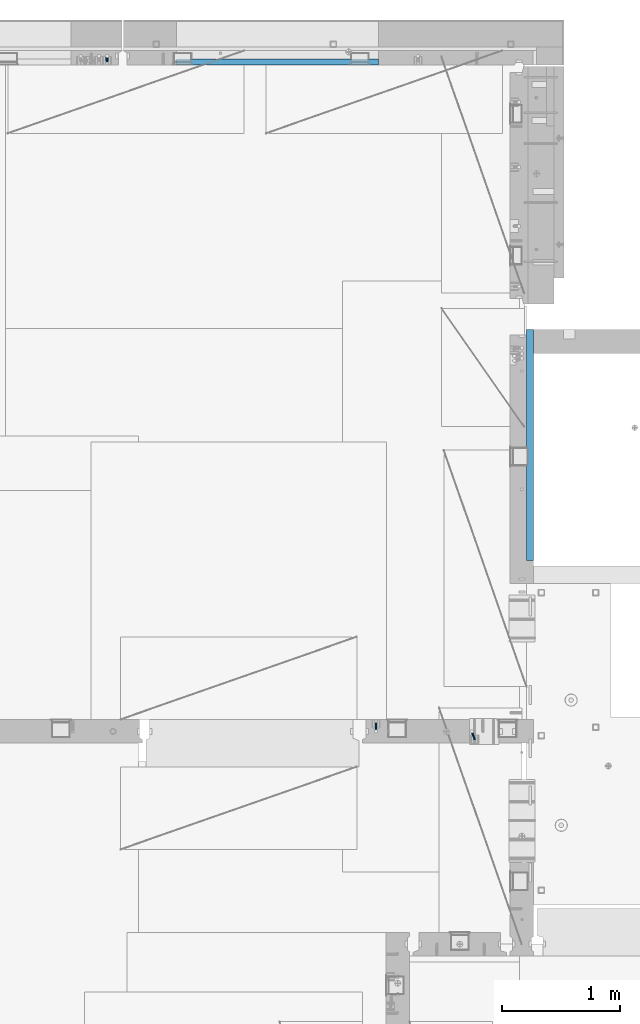
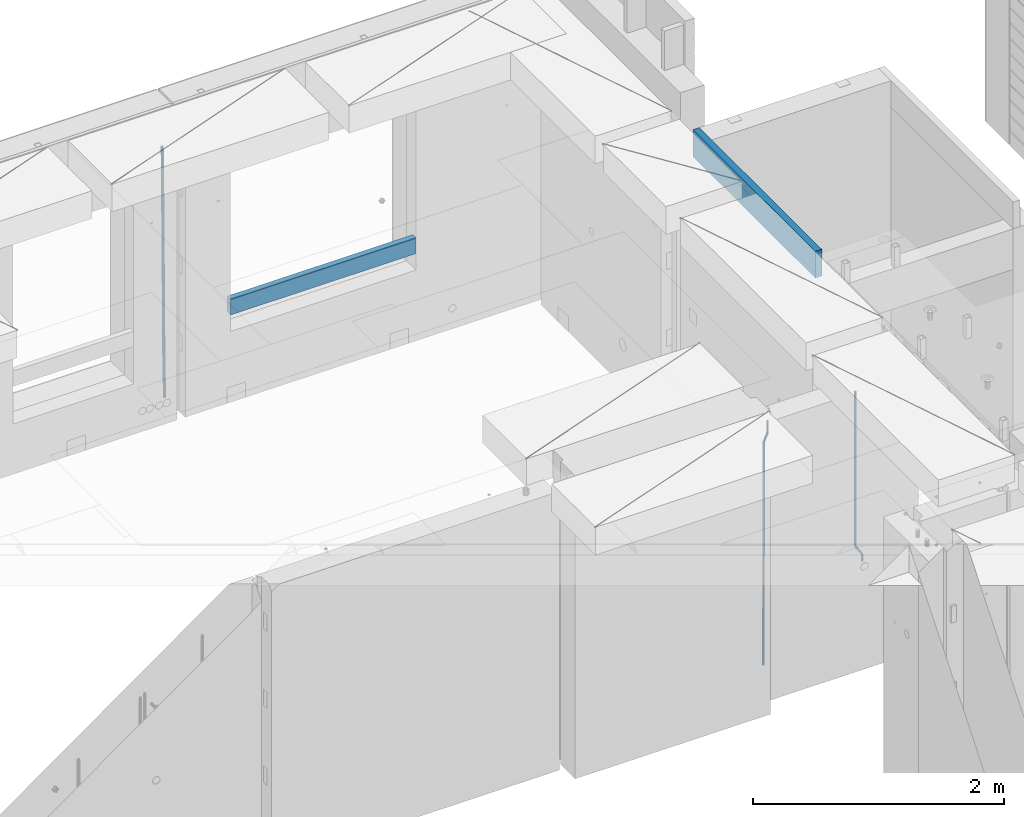
# One storey, part 101 of 309: 6 beams, 5 elements without a shape of their own.
"""IFC2X3 building model written with IfcOpenShell, lengths in millimetres."""

from ifc_helpers import new_model, si_unit, frame, origin_with_axes, place, context, subcontext, project, spatial, faceted_brep, material, type_object, element, aggregate, save


model = new_model("IFC2X3")

# Units and contexts
model_context = context("Model", 3, precision=1e-05, world=origin_with_axes())
body_context = subcontext(model_context, "Body", "Model", "MODEL_VIEW")
ifc_project = project(units=[si_unit("LENGTHUNIT", "METRE", prefix="MILLI"), si_unit("AREAUNIT", "SQUARE_METRE"), si_unit("VOLUMEUNIT", "CUBIC_METRE"), si_unit("MASSUNIT", "GRAM", prefix="KILO"), si_unit("TIMEUNIT", "SECOND"), si_unit("PLANEANGLEUNIT", "RADIAN"), si_unit("SOLIDANGLEUNIT", "STERADIAN"), si_unit("THERMODYNAMICTEMPERATUREUNIT", "DEGREE_CELSIUS"), si_unit("LUMINOUSINTENSITYUNIT", "LUMEN")], contexts=[model_context])

# Site, building, storey
site_placement = place(None, origin_with_axes())
site = spatial("IfcSite", under=ifc_project, at=site_placement, CompositionType="ELEMENT")
building_placement = place(site_placement, origin_with_axes())
building = spatial("IfcBuilding", under=site, at=building_placement, CompositionType="ELEMENT")
storey_placement = place(building_placement, origin_with_axes())
storey = spatial("IfcBuildingStorey", under=building, at=storey_placement, Name="7", CompositionType="ELEMENT", Elevation=0.0)

# Assembly, beams
assembly_1_placement = place(storey_placement, origin_with_axes())
assembly_1 = element("IfcElementAssembly", 1, at=assembly_1_placement, inside=storey, AssemblyPlace="NOTDEFINED", PredefinedType="REINFORCEMENT_UNIT")
ifc_material_1 = material()
beam_type_1 = type_object("IfcBeamType", Name="D20", PredefinedType="NOTDEFINED")
beam_1_placement = place(assembly_1_placement, frame((17285.016478657, 16980.0, 102407.5), z_axis=(-0.000415599999849952, -0.999999913638316, 0.0), x_axis=(-6.05680000062309e-05, -4.00000390151988e-09, -0.999999998165759)))
beam_1 = element("IfcBeam", 2, at=beam_1_placement, type_object=beam_type_1, material=ifc_material_1, Name="JM20", ObjectType="D20", context=body_context, shape_type="Brep", body=[
    faceted_brep([(0.000459931368823163, -9.99999998942076, 0.0), (0.000325058383168653, -7.07106780439426, -7.07106781187031), (1498.53016917036, -7.00214571310062, -7.07110244258729), (1498.53030404639, -9.93107788867201, -3.46394881489687e-05), (0.0, 0.0, -10.0), (1498.52984388257, 0.0689220912790915, -10.0000346307206), (-0.000325382832670584, 7.07106780437971, -7.07106781186667), (1498.52951872915, 7.13998989566971, -7.07110244258365), (-0.000459931412478909, 9.9999999894244, 0.0), (1498.52938418057, 10.0689220807144, -3.46307206200436e-05), (-0.000325058426824398, 7.07106780439062, 7.07106781186667), (1498.52951905355, 7.13998989568427, 7.07103318114605), (0.0, 0.0, 10.0), (1498.52984434133, 0.0689220913009194, 9.99996536927938), (0.000325382789014839, -7.07106780437607, 7.07106781186303), (1498.53016949476, -7.00214571308607, 7.07103318114241), (1512.41720874803, -5.73582294623338, -3.78448857876356), (1509.77427058959, -8.90577003658836, 2.66104918808924), (1506.12781116656, -6.30933666407145, 8.86914963737581), (1503.61387695429, 0.5325217154641, 11.203191722434), (1503.70509651935, 7.6119372551475, 8.29592524499458), (1506.34803467779, 10.7818843455061, 1.85038747814542), (1509.99449410092, 8.18545097300375, -4.35771297110477), (1512.50842831319, 1.34359259344637, -6.6917550561775), (1523.10793428493, 4.85819958866705, 2.43339327473223), (1522.94729923509, -2.24423288682374, 5.28089974098111), (1518.68801206884, 11.068066365151, 3.12656423834051), (1512.27666307625, 12.7477117054659, 6.95436248228361), (1507.62956859401, 8.91322214926913, 11.6745157093537), (1507.46893354415, 1.81078967378926, 14.5220221756208), (1511.88885576031, -4.39907710268017, 13.8288512120525), (1518.30020474852, -6.07872245333419, 10.0010529750907), (1556.47190306216, 16.2553988912259, 53.3150705600565), (1551.82480858495, 12.4209093455574, 58.0352237797015), (1556.63253811194, 23.3578313666767, 50.4675640938258), (1552.2126158958, 29.5676981431861, 51.1607350575687), (1545.80126690332, 31.2473434836029, 54.9885333017664), (1541.1541724212, 27.4128539274789, 59.7086865290003), (1540.99353737144, 20.3104214520208, 62.5561929952273), (1545.41345958759, 14.100554675515, 61.8630220314881), (1560.39637396604, 17.5567067062075, 56.6936612143036), (1557.75345399432, 14.386777545431, 63.1392152562548), (1554.10697584673, 16.9832211248868, 69.3473004384578), (1551.59299696748, 23.8250760096525, 71.6813046576062), (1551.6841720884, 30.9044764000282, 68.7739998967481), (1554.32709206025, 34.0744055607975, 62.3284458548405), (1557.97357020773, 31.4779619813417, 56.1203606726085), (1560.48754908697, 24.6361070965759, 53.7863564534418), (1565.57152260729, 25.0997628321384, 54.9895678972971), (1565.57195097132, 18.0287166318594, 57.9185522284643), (1565.57109441068, 32.1708522292429, 57.9184479422765), (1565.5709172132, 35.0998365550477, 64.9894941556158), (1565.57109481466, 32.1709565155361, 72.0605835657152), (1565.57152317863, 25.0999103152426, 74.9895678968714), (1565.5719513753, 18.0288209181526, 72.0606878518956), (1565.57212857006, 15.0998365824271, 64.9896416479532), (1617.49891294041, 18.0318617339399, 57.9185507229813), (1617.49909054188, 15.1029816944028, 64.9896401330443), (1617.49848457637, 25.1029079342443, 54.989566391796), (1617.49805637961, 32.1739973313524, 57.9184464367172), (1617.49787918197, 35.1029816571718, 64.9894926500019), (1617.49805678344, 32.1741016176347, 72.0605820600649), (1617.49848514747, 25.1030554173267, 74.9895663912539), (1617.49891334424, 18.0319660202294, 72.060686346329)], [[[0, 1, 2, 3]], [[1, 4, 5, 2]], [[4, 6, 7, 5]], [[6, 8, 9, 7]], [[8, 10, 11, 9]], [[10, 12, 13, 11]], [[12, 14, 15, 13]], [[14, 0, 3, 15]], [[14, 12, 10, 8, 6, 4, 1, 0]], [[3, 2, 16, 17]], [[15, 3, 17, 18]], [[13, 15, 18, 19]], [[11, 13, 19, 20]], [[9, 11, 20, 21]], [[7, 9, 21, 22]], [[5, 7, 22, 23]], [[2, 5, 23, 16]], [[23, 24, 25, 16]], [[22, 26, 24, 23]], [[21, 27, 26, 22]], [[20, 28, 27, 21]], [[19, 29, 28, 20]], [[18, 30, 29, 19]], [[17, 31, 30, 18]], [[16, 25, 31, 17]], [[31, 25, 32, 33]], [[25, 24, 34, 32]], [[24, 26, 35, 34]], [[26, 27, 36, 35]], [[27, 28, 37, 36]], [[28, 29, 38, 37]], [[29, 30, 39, 38]], [[30, 31, 33, 39]], [[33, 32, 40, 41]], [[39, 33, 41, 42]], [[38, 39, 42, 43]], [[37, 38, 43, 44]], [[36, 37, 44, 45]], [[35, 36, 45, 46]], [[34, 35, 46, 47]], [[32, 34, 47, 40]], [[47, 48, 49, 40]], [[46, 50, 48, 47]], [[45, 51, 50, 46]], [[44, 52, 51, 45]], [[43, 53, 52, 44]], [[42, 54, 53, 43]], [[41, 55, 54, 42]], [[40, 49, 55, 41]], [[55, 49, 56, 57]], [[49, 48, 58, 56]], [[48, 50, 59, 58]], [[50, 51, 60, 59]], [[51, 52, 61, 60]], [[52, 53, 62, 61]], [[53, 54, 63, 62]], [[54, 55, 57, 63]], [[58, 59, 60, 61, 62, 63, 57, 56]]]),
])
beam_2_placement = place(assembly_1_placement, frame((16475.016478657, 16980.0, 102407.5), z_axis=(-0.000415599999849952, -0.999999913638316, 0.0), x_axis=(-6.05680000062309e-05, -4.00000390151988e-09, -0.999999998165759)))
beam_2 = element("IfcBeam", 3, at=beam_2_placement, type_object=beam_type_1, material=ifc_material_1, Name="JM20", ObjectType="D20", context=body_context, shape_type="Brep", body=[
    faceted_brep([(-0.00060564729210455, -9.99999998165731, 0.0), (-0.000428079845733009, -7.07106779890455, -7.07106781186667), (109.663992146438, -7.07770969181365, -7.07106505070624), (109.663814574931, -10.0066418742208, 2.76014907285571e-06), (0.0, 0.0, -10.0), (109.664420484245, -0.00664189292001538, -9.99999723883957), (0.00042843479604926, 7.07106779888636, -7.07106781186303), (109.66484867355, 7.0644259059809, -7.07106505070988), (0.00060564729210455, 9.99999998166459, 3.63797880709171e-12), (109.665025886861, 9.99335808875549, 2.76115679298528e-06), (0.000428079845733009, 7.07106779890819, 7.07106781186667), (109.664848315049, 7.06442590600273, 7.07107057301982), (0.0, 0.0, 10.0), (109.664419977242, -0.00664189288727357, 10.0000027611604), (-0.000428434810601175, -7.07106779888272, 7.07106781186667), (109.663991787937, -7.07770969179182, 7.07107057302346), (123.019465653822, -0.00769783093346632, 8.49481275451399), (122.368218641306, 7.06342149385819, 5.63932810477127), (120.794596020874, 9.9924781119953, -1.25436342694593), (119.220404581531, 7.06367038153257, -8.14803083615698), (118.567784318744, -0.00734585062309634, -11.0034572490222), (119.219031331319, -7.07846517541839, -8.14797259927946), (120.79265395175, -10.0075217935628, -1.25428106757317), (122.366845391021, -7.07871406308914, 5.63938634164515), (134.432358609134, -7.0801380724879, 1.41616492140383), (135.704448506891, -0.00919495208290755, 4.05476198080942), (131.363125973905, -10.0087693538771, -4.95420191149606), (128.294665451453, -7.07953630984775, -11.3246640276848), (127.024439601548, -0.00834393120385357, -13.9634911148387), (128.296529499246, 7.06259918918295, -11.3248940553931), (131.365762135116, 9.99123047017565, -4.95452722118716), (134.434222657001, 7.06199742654644, 1.41593489364823), (232.333181448281, -7.09406463311461, -61.4435769522424), (235.401641971155, -10.0232976755033, -55.0731148385494), (231.062955598129, -0.0228722546671634, -64.0824040398293), (232.335045495653, 7.04807086590154, -61.4438069808093), (235.404278131435, 9.97670214732716, -55.0734401467271), (238.472738653494, 7.0474691041527, -48.7029780316807), (239.742964503646, -0.0237232742911146, -46.0641509440975), (238.470874606137, -7.09466639485981, -48.7027480031138), (248.152386176487, -0.0244396446978499, -49.0133708264948), (247.497266945589, 7.04670033489674, -51.8679184167595), (245.915123067214, 9.97580676374491, -58.7596380886316), (244.332752967632, 7.04704882145597, -65.6514539264135), (243.677087590491, -0.0239468102772662, -68.5062336817027), (244.33220682136, -7.09508678989368, -65.651686091438), (245.914350699837, -10.0241932187346, -58.7599664195659), (247.496720799376, -7.09543527645292, -51.8681505817658), (256.999396693936, -7.09531210125351, -52.9566469665442), (257.006072236094, -0.0243248818260327, -50.0275278254703), (256.982439129002, -10.0240497531304, -60.0277750206151), (256.965133057005, -7.09492303985826, -67.0987410777925), (256.957616135987, -0.0237746659149707, -70.0274691179584), (256.964291678203, 7.04721255350523, -67.0983499769027), (256.981249241362, 9.97595020465087, -60.027221921624), (256.998555315135, 7.04682349210998, -52.9562558656398), (2308.84129044529, -6.97271028710384, -72.0700484847293), (2308.85859651901, -9.9018369995174, -64.9990824287343), (2308.83377352433, 0.0984380867485015, -74.9987765249425), (2308.84044906651, 7.16942530619053, -72.0696573839123), (2308.85740662973, 10.0981629574344, -64.9985293286554), (2308.87471270347, 7.16903624502447, -57.9275632726531), (2308.88222962443, 0.0978878711684956, -54.9988352324472), (2308.87555408225, -6.9730993482699, -57.9279543734738), (2309.36197244871, -6.97267927451685, -72.0713099986351), (2309.37071429225, -9.90180649703325, -65.000323193126), (2309.3579998037, 0.0984693104364851, -75.0000466259553), (2309.3611234788, 7.16945631832277, -72.0709188794244), (2309.36951366749, 10.0981934592819, -64.9997700670392), (2309.37825551104, 7.16906623676914, -57.9287832615337), (2309.38222815606, 0.0979176518158056, -55.0000466342135), (2309.37910448095, -6.97306935607776, -57.929174380748), (2309.8826559803, -6.97264773775169, -72.0713100117428), (2309.88283356852, -9.90177547898566, -65.0003232060189), (2309.88222762165, 0.0985010618751403, -75.0000466391502), (2309.88179941924, 7.16948785463319, -72.0709188925321), (2309.88162220824, 10.0982244766819, -64.9997700799322), (2309.88179979647, 7.16909673544797, -57.9287832742084), (2309.88222815514, 0.0979479358211393, -55.0000466468009), (2309.88265635754, -6.97303885693691, -57.9291743934191), (2417.50042500655, -6.96612954309967, -72.0713127206036), (2417.50060259478, -9.89525728433364, -65.0003259148798), (2417.49999664789, 0.105019256523519, -75.0000493480147), (2417.49956844548, 7.17600604928157, -72.0709216013965), (2417.49939123449, 10.1047426713303, -64.9997727887931), (2417.49956882271, 7.17561493009634, -57.9287859830729), (2417.49999718138, 0.104466130473156, -55.0000493556618), (2417.50042538378, -6.96652066228489, -57.9291771022799)], [[[0, 1, 2, 3]], [[1, 4, 5, 2]], [[4, 6, 7, 5]], [[6, 8, 9, 7]], [[8, 10, 11, 9]], [[10, 12, 13, 11]], [[12, 14, 15, 13]], [[14, 0, 3, 15]], [[14, 12, 10, 8, 6, 4, 1, 0]], [[11, 13, 16, 17]], [[9, 11, 17, 18]], [[7, 9, 18, 19]], [[5, 7, 19, 20]], [[2, 5, 20, 21]], [[3, 2, 21, 22]], [[15, 3, 22, 23]], [[13, 15, 23, 16]], [[23, 24, 25, 16]], [[22, 26, 24, 23]], [[21, 27, 26, 22]], [[20, 28, 27, 21]], [[19, 29, 28, 20]], [[18, 30, 29, 19]], [[17, 31, 30, 18]], [[16, 25, 31, 17]], [[26, 27, 32, 33]], [[27, 28, 34, 32]], [[28, 29, 35, 34]], [[29, 30, 36, 35]], [[30, 31, 37, 36]], [[31, 25, 38, 37]], [[25, 24, 39, 38]], [[24, 26, 33, 39]], [[37, 38, 40, 41]], [[36, 37, 41, 42]], [[35, 36, 42, 43]], [[34, 35, 43, 44]], [[32, 34, 44, 45]], [[33, 32, 45, 46]], [[39, 33, 46, 47]], [[38, 39, 47, 40]], [[47, 48, 49, 40]], [[46, 50, 48, 47]], [[45, 51, 50, 46]], [[44, 52, 51, 45]], [[43, 53, 52, 44]], [[42, 54, 53, 43]], [[41, 55, 54, 42]], [[40, 49, 55, 41]], [[50, 51, 56, 57]], [[51, 52, 58, 56]], [[52, 53, 59, 58]], [[53, 54, 60, 59]], [[54, 55, 61, 60]], [[55, 49, 62, 61]], [[49, 48, 63, 62]], [[48, 50, 57, 63]], [[57, 56, 64, 65]], [[56, 58, 66, 64]], [[58, 59, 67, 66]], [[59, 60, 68, 67]], [[60, 61, 69, 68]], [[61, 62, 70, 69]], [[62, 63, 71, 70]], [[63, 57, 65, 71]], [[65, 64, 72, 73]], [[64, 66, 74, 72]], [[66, 67, 75, 74]], [[67, 68, 76, 75]], [[68, 69, 77, 76]], [[69, 70, 78, 77]], [[70, 71, 79, 78]], [[71, 65, 73, 79]], [[73, 72, 80, 81]], [[72, 74, 82, 80]], [[74, 75, 83, 82]], [[75, 76, 84, 83]], [[76, 77, 85, 84]], [[77, 78, 86, 85]], [[78, 79, 87, 86]], [[79, 73, 81, 87]], [[82, 83, 84, 85, 86, 87, 81, 80]]]),
])
aggregate(assembly_1, [beam_1, beam_2])

# Assembly, beam
assembly_2_placement = place(storey_placement, origin_with_axes())
assembly_2 = element("IfcElementAssembly", 4, at=assembly_2_placement, inside=storey, AssemblyPlace="NOTDEFINED", PredefinedType="REINFORCEMENT_UNIT")
ifc_material_2 = material(Name="CONCRETE/C25/30")
beam_type_2 = type_object("IfcBeamType", Name="260X60", PredefinedType="NOTDEFINED")
beam_3_placement = place(assembly_2_placement, frame((17779.9999105288, 18424.9992663657, 102600.0), z_axis=(0.0, 0.0, 1.0), x_axis=(0.0, 1.0, 0.0)))
beam_3 = element("IfcBeam", 5, at=beam_3_placement, type_object=beam_type_2, material=ifc_material_2, ObjectType="260X60", context=body_context, shape_type="Brep", body=[
    faceted_brep([(0.0, 30.0, -130.0), (0.0, 30.0, 130.0), (1954.9989445891, 30.0, 130.0), (1954.9989445891, 30.0, -130.0), (0.0, -30.0, 130.0), (1954.9989445891, -30.0, 130.0), (0.0, -30.0, -130.0), (1954.9989445891, -30.0, -130.0)], [[[0, 1, 2, 3]], [[1, 4, 5, 2]], [[4, 6, 7, 5]], [[6, 0, 3, 7]], [[5, 7, 3, 2]], [[6, 4, 1, 0]]]),
])
aggregate(assembly_2, [beam_3])

assembly_3_placement = place(storey_placement, origin_with_axes())
assembly_3 = element("IfcElementAssembly", 6, at=assembly_3_placement, inside=storey, AssemblyPlace="NOTDEFINED", PredefinedType="REINFORCEMENT_UNIT")
beam_type_3 = type_object("IfcBeamType", Name="D25", PredefinedType="NOTDEFINED")
beam_4_placement = place(assembly_3_placement, frame((14200.1300000039, 22654.999995444, 99989.68), z_axis=(-0.000205762999925498, 0.999642804629538, -0.0267249099901004), x_axis=(4.30000201928125e-08, 0.0267249099948059, 0.999642825806181)))
beam_4 = element("IfcBeam", 7, at=beam_4_placement, type_object=beam_type_3, material=ifc_material_1, Name="JM25", ObjectType="D25", context=body_context, shape_type="Brep", body=[
    faceted_brep([(-7.41420080885291e-08, -12.5, -3.63797880709171e-12), (-6.42030499875546e-08, -10.8253175473074, -6.25000000000364), (60.3237677085563, -10.8253175348218, -6.24999999383726), (60.3237677118304, -12.4999999875163, 6.16273609921336e-09), (-3.70782800018787e-08, -6.25000000000364, -10.8253175473074), (60.3237677054713, -6.24999998751628, -10.825317541141), (-1.45519152283669e-11, -3.63797880709171e-12, -12.5), (60.3237677033903, 1.24837242765352e-08, -12.4999999938373), (3.70637280866504e-08, 6.25, -10.8253175473074), (60.323767702881, 6.25000001248372, -10.825317541141), (6.42030499875546e-08, 10.8253175473001, -6.25000000000364), (60.3237677040888, 10.8253175597911, -6.24999999383726), (7.41420080885291e-08, 12.4999999999927, 0.0), (60.3237677066645, 12.5000000124837, 6.15909812040627e-09), (6.42176019027829e-08, 10.8253175473001, 6.24999999999636), (60.3237677099241, 10.8253175597893, 6.25000000616274), (3.70928319171071e-08, 6.24999999999636, 10.8253175473037), (60.3237677130091, 6.25000001248554, 10.8253175534701), (1.45519152283669e-11, -3.63797880709171e-12, 12.4999999999964), (60.3237677151046, 1.24837242765352e-08, 12.5000000061627), (-3.7049176171422e-08, -6.25000000000364, 10.8253175473001), (60.3237677156139, -6.24999998751628, 10.8253175534701), (-6.41884980723262e-08, -10.8253175473074, 6.25), (60.3237677144207, -10.82531753482, 6.25000000616274), (61.0758245489851, -10.8253175346654, -6.24999999375723), (60.991802792938, -12.4999999843931, 6.22458173893392e-09), (61.1373109934648, -6.24999998734893, -10.8253175410573), (61.1598041100515, 1.26583472592756e-08, -12.49999999375), (61.1372768863075, 6.25000001265289, -10.8253175410609), (61.0757654736371, 10.8253175599439, -6.24999999376087), (60.9917690322181, 12.5000000156033, 6.22458173893392e-09), (60.907747276171, 10.8253175599111, 6.25000000622094), (60.8462608316913, 6.25000001259286, 10.8253175535247), (60.8237677151046, 1.25892256619409e-08, 12.5000000062173), (60.8462949388486, -6.24999998740714, 10.825317553521), (60.9078063515044, -10.8253175347018, 6.25000000622458), (61.8276096861373, -10.8253134314764, -6.22978616751061), (61.6596309735614, -12.4999963425144, 0.017955953906494), (61.9505603643775, -6.24999554869282, -10.8034510785947), (61.9955384732893, 4.57403257314581e-06, -12.4775289599711), (61.950492164935, 6.25000445112164, -10.8034519952598), (61.827491561271, 10.8253216628109, -6.22978775521551), (61.6594945747056, 12.5000036571128, 0.0179541205834539), (61.4915158621152, 10.8253207460766, 6.26569624199692), (61.3685651839041, 6.25000286329123, 10.8393611530882), (61.3235870749922, 2.74056583293714e-06, 12.5134390344683), (61.3686333833321, -6.24999713652323, 10.8393620697534), (61.491633986996, -10.8253143482107, 6.26569782971274), (146.560019984419, -10.8248509682762, -3.95152056365259), (146.392041271829, -12.4995338793105, 2.29622155776815), (146.682970662645, -6.24953308548902, -8.52518547473665), (146.727948771557, 0.000467037238195189, -10.1992633561131), (146.682902463217, 6.25046691432544, -8.5251863914018), (146.559901859553, 10.8257841260165, -3.95152215136113), (146.391904872988, 12.5004661203184, 2.29621972444511), (146.223926160397, 10.8257832092804, 8.54396184585858), (146.100975482186, 6.25046532649503, 13.1176267569463), (146.05599737326, 0.000465203767817002, 14.7917046383263), (146.1010436816, -6.24953467331943, 13.1176276736078), (146.224044285264, -10.8248518850105, 8.54396343356711), (147.111078313566, -10.8248479606373, -3.93670383375138), (146.994353869159, -12.4995305919347, 2.31241640066946), (147.196513863179, -6.24953028260825, -8.5113774430065), (147.227768131459, 0.000469765214802464, -10.1858243278657), (147.19646656244, 6.25046971732081, -8.51137779775308), (147.110996386313, 10.8257871338483, -3.93670444818781), (146.994259267696, 12.5004694079234, 2.31241569117628), (146.877534823288, 10.8257867766279, 8.56153592559713), (146.792099273691, 6.25046909859884, 13.1362095348559), (146.760845005425, 0.000469050775791402, 14.8106564197114), (146.792146574429, -6.24953090133022, 13.1362098895952), (146.877616750571, -10.8248483178577, 8.56153654003356), (147.662305566744, -10.824846796575, -3.93093035933998), (147.596851102222, -12.4995293196007, 2.31872686942006), (147.710214487655, -6.24952919779389, -8.50599701707324), (147.727740708287, 0.000470821039925795, -10.1805876875078), (147.710188092009, 6.25047080218064, -8.50599715285716), (147.662259848148, 10.8257882979869, -3.93093059453167), (147.596798310929, 12.5004706803447, 2.31872659784494), (147.531343846407, 10.825788157319, 8.56838382660862), (147.483434925496, 6.25047055853611, 13.1434504843382), (147.465908704849, 0.000470539705929696, 14.8180411547801), (147.483461321142, -6.24952944143479, 13.1434506201294), (147.531389565032, -10.8248469372429, 8.56838406180032), (299.377341023079, -10.8245264100169, -2.34188905237897), (299.311886558571, -12.4992089330408, 3.90776817638471), (299.425249944004, -6.24920881123398, -6.9169557101086), (299.442776164637, 0.000791207598012988, -8.59154638054679), (299.425223548358, 6.25079118874055, -6.91695584589979), (299.377295304497, 10.8261086845469, -2.34188928757067), (299.311833767279, 12.5007910669028, 3.90776790480959), (299.246379302756, 10.8261085438789, 10.1574251335696), (299.198470381845, 6.25079094509601, 14.7324917913029), (299.180944161213, 0.000790926264016889, 16.4070824617411), (299.198496777492, -6.24920905487488, 14.7324919270868), (299.246425021367, -10.8245265506848, 10.157425368765), (299.95725460563, -10.824525185375, -2.33581512151068), (299.97179243555, -12.4991882411778, 3.91467976726199), (299.946633883446, -6.24920771019424, -6.91149481024331), (299.942748741494, 0.000792263424955308, -8.58630974019252), (299.946640200433, 6.25079228984941, -6.91149460340603), (299.957265546982, 10.8261099093088, -2.33581476325344), (299.971750386685, 12.5008117588586, 3.91467993563856), (299.98628821662, 10.8261101063945, 10.1651748323675), (299.996908938818, 6.25079263121188, 14.7408545211001), (300.000794080755, 0.000792657594502089, 16.415669451053), (299.996902621817, -6.24920736882996, 14.7408543142628), (299.986277275268, -10.8245249882893, 10.1651744741102), (300.537133734106, -10.8245269960826, -2.3445816610074), (300.631604424707, -12.4992095999223, 3.90470428084518), (300.467986846197, -6.24920933814974, -6.91937655855145), (300.442691613745, 0.000790702320955461, -8.59386781345165), (300.468025873881, 6.25079066179023, -6.91937684622826), (300.537201332045, 10.8261080984212, -2.34458215927589), (300.631682480074, 12.5007903999558, 3.90470370549519), (300.726153170675, 10.8261077961179, 10.1539896473478), (300.795300058599, 6.25079013818504, 14.7287845448955), (300.82059529105, 0.000790097714343574, 16.403275799792), (300.795261030915, -6.24920986175493, 14.7287848325686), (300.726085572751, -10.8245272983859, 10.1539901456163), (2293.32930409742, -10.8307295605009, -32.4713622331001), (2293.42377478865, -12.5054121599169, -26.2220762900724), (2293.26015720774, -6.2554119058077, -37.0461571338565), (2293.23486197284, -0.00541186651753378, -38.7206483931477), (2293.26019623051, 6.24458809413409, -37.0461574303008), (2293.32937168686, 10.8199055340046, -32.4713627465644), (2293.42385283421, 12.4945878399631, -26.2220768829684), (2293.51832352545, 10.8199052405434, -19.972790939948), (2293.58747041514, 6.24458758585388, -15.3979960391844), (2293.61276565003, -0.00541245343265473, -13.7235047798931), (2293.58743139236, -6.25541241408428, -15.3979957427327), (2293.51825593603, -10.8307298539585, -19.9727904264691), (2294.0420846676, -10.8307317859326, -32.4821379598216), (2294.03681932652, -12.5054140739521, -26.2313442200393), (2294.06778164886, -6.2554144273563, -37.0583666982457), (2294.10702478497, -0.00541458957013674, -38.7338336404937), (2294.14929890928, 6.24458531819619, -37.0595987724118), (2294.18327670435, 10.8199028679592, -32.4842719748667), (2294.1998538474, 12.4945854171456, -26.2338083683717), (2294.19458850632, 10.819903129126, -19.9830146285858), (2294.16889152506, 6.24458577054975, -15.4067858901581), (2294.12964838895, -0.0054140672327776, -13.7313189479173), (2294.08737426462, -6.2554139749991, -15.4055538159919), (2294.05339646956, -10.8307315247621, -19.9808806135297), (2294.75482297382, -10.84002603931, -32.4726521173216), (2294.64982751427, -12.513407826169, -26.2231856868602), (2294.87535820232, -6.26594539088183, -37.0476186524102), (2294.97913588268, -0.0167870967634371, -38.7222267036377), (2295.0383488692, 6.23299192477134, -37.0477663960555), (2295.03713108998, 10.8087684320271, -32.4729080168181), (2294.97580884799, 12.4844668051373, -26.2234811741473), (2294.87081338844, 10.8110850182784, -19.9740147436787), (2294.7502781599, 6.23700436985018, -15.3990482086047), (2294.64650047956, -0.0121539242718427, -13.7244401573698), (2294.58728749304, -6.26193294580662, -15.3989004649666), (2294.58850527227, -10.8377094530588, -19.9737588441894), (2316.44667268227, -11.1228921988077, -32.1839550346631), (2316.34167722271, -12.7962739856739, -25.9344886042054), (2316.56720791078, -6.54881155039038, -36.7589215697517), (2316.67098559113, -0.299653256264719, -38.4335296209792), (2316.73019857766, 5.95012576527006, -36.759069313397), (2316.72898079845, 10.5259022725259, -32.1842109341669), (2316.66765855643, 12.2016006456361, -25.9347840914961), (2316.56266309689, 10.5282188587698, -19.6853176610275), (2316.44212786836, 5.95413821035254, -15.1103511259389), (2316.33835018802, -0.295020083769487, -13.4357430747186), (2316.27913720149, -6.54479910530426, -15.1102033823008), (2316.28035498071, -11.1205756125637, -19.685061761531), (2317.13234804722, -11.1318335458927, -32.1748293731798), (2317.04181141085, -12.8054038787741, -25.9251705100723), (2317.2154741603, -6.5572650749491, -36.7502937866229), (2317.26891617525, -0.307450393454928, -38.4255717558117), (2317.27835434731, 5.94297770185585, -36.7517739018112), (2317.24125972588, 10.5192220504723, -32.1773930078925), (2317.16757178486, 12.1950816748285, -25.9281307404563), (2317.0770351485, 10.5215113419545, -19.6784718773561), (2316.99390903539, 5.94694287101083, -15.1030074639057), (2316.94046702047, -0.302871810494253, -13.4277294947169), (2316.9310288484, -6.55329990579412, -15.1015273487101), (2316.96812346982, -11.1295442544142, -19.6759082426288), (2317.81808136747, -11.1298054502913, -32.1659056455355), (2317.74200467508, -12.803315894289, -25.9160547315114), (2317.86379538118, -6.55536082026447, -36.7418676070083), (2317.8668976831, -0.305700748642266, -38.417815303761), (2317.82655701396, 5.94458339541234, -36.7446799039099), (2317.75358262347, 10.5207330230332, -32.1707766866384), (2317.66752794063, 12.1965725370646, -25.9216793252963), (2317.59145124823, 10.5230620930706, -19.6718284112721), (2317.54573723453, 5.94861746304377, -15.0958664497994), (2317.54263493262, -0.301042608574789, -13.4199187530394), (2317.58297560175, -6.55132675263303, -15.0930541529051), (2317.65594999224, -11.1274763802539, -19.6669573701693), (2417.81884292323, -10.831603083323, -30.8687911350135), (2417.74276623082, -12.505113527317, -24.618940220982), (2417.86455693691, -6.25715845329614, -35.4447530964935), (2417.86765923884, -0.00749838167394046, -37.1207007932499), (2417.82731856969, 6.24278576237703, -35.4475653933878), (2417.75434417921, 10.8189353900088, -30.8736621761236), (2417.66828949639, 12.494774904033, -24.6245648147851), (2417.59221280397, 10.8212644600353, -18.3747139007501), (2417.54649879028, 6.2468198300121, -13.79875193927), (2417.54339648837, -0.00284024161010166, -12.1228042425173), (2417.5837371575, -6.25312438566107, -13.795939642383), (2417.65671154798, -10.8292740132893, -18.3698428596399)], [[[0, 1, 2, 3]], [[1, 4, 5, 2]], [[4, 6, 7, 5]], [[6, 8, 9, 7]], [[8, 10, 11, 9]], [[10, 12, 13, 11]], [[12, 14, 15, 13]], [[14, 16, 17, 15]], [[16, 18, 19, 17]], [[18, 20, 21, 19]], [[20, 22, 23, 21]], [[22, 0, 3, 23]], [[22, 20, 18, 16, 14, 12, 10, 8, 6, 4, 1, 0]], [[3, 2, 24, 25]], [[2, 5, 26, 24]], [[5, 7, 27, 26]], [[7, 9, 28, 27]], [[9, 11, 29, 28]], [[11, 13, 30, 29]], [[13, 15, 31, 30]], [[15, 17, 32, 31]], [[17, 19, 33, 32]], [[19, 21, 34, 33]], [[21, 23, 35, 34]], [[23, 3, 25, 35]], [[25, 24, 36, 37]], [[24, 26, 38, 36]], [[26, 27, 39, 38]], [[27, 28, 40, 39]], [[28, 29, 41, 40]], [[29, 30, 42, 41]], [[30, 31, 43, 42]], [[31, 32, 44, 43]], [[32, 33, 45, 44]], [[33, 34, 46, 45]], [[34, 35, 47, 46]], [[35, 25, 37, 47]], [[37, 36, 48, 49]], [[36, 38, 50, 48]], [[38, 39, 51, 50]], [[39, 40, 52, 51]], [[40, 41, 53, 52]], [[41, 42, 54, 53]], [[42, 43, 55, 54]], [[43, 44, 56, 55]], [[44, 45, 57, 56]], [[45, 46, 58, 57]], [[46, 47, 59, 58]], [[47, 37, 49, 59]], [[49, 48, 60, 61]], [[48, 50, 62, 60]], [[50, 51, 63, 62]], [[51, 52, 64, 63]], [[52, 53, 65, 64]], [[53, 54, 66, 65]], [[54, 55, 67, 66]], [[55, 56, 68, 67]], [[56, 57, 69, 68]], [[57, 58, 70, 69]], [[58, 59, 71, 70]], [[59, 49, 61, 71]], [[61, 60, 72, 73]], [[60, 62, 74, 72]], [[62, 63, 75, 74]], [[63, 64, 76, 75]], [[64, 65, 77, 76]], [[65, 66, 78, 77]], [[66, 67, 79, 78]], [[67, 68, 80, 79]], [[68, 69, 81, 80]], [[69, 70, 82, 81]], [[70, 71, 83, 82]], [[71, 61, 73, 83]], [[73, 72, 84, 85]], [[72, 74, 86, 84]], [[74, 75, 87, 86]], [[75, 76, 88, 87]], [[76, 77, 89, 88]], [[77, 78, 90, 89]], [[78, 79, 91, 90]], [[79, 80, 92, 91]], [[80, 81, 93, 92]], [[81, 82, 94, 93]], [[82, 83, 95, 94]], [[83, 73, 85, 95]], [[85, 84, 96, 97]], [[84, 86, 98, 96]], [[86, 87, 99, 98]], [[87, 88, 100, 99]], [[88, 89, 101, 100]], [[89, 90, 102, 101]], [[90, 91, 103, 102]], [[91, 92, 104, 103]], [[92, 93, 105, 104]], [[93, 94, 106, 105]], [[94, 95, 107, 106]], [[95, 85, 97, 107]], [[97, 96, 108, 109]], [[96, 98, 110, 108]], [[98, 99, 111, 110]], [[99, 100, 112, 111]], [[100, 101, 113, 112]], [[101, 102, 114, 113]], [[102, 103, 115, 114]], [[103, 104, 116, 115]], [[104, 105, 117, 116]], [[105, 106, 118, 117]], [[106, 107, 119, 118]], [[107, 97, 109, 119]], [[109, 108, 120, 121]], [[108, 110, 122, 120]], [[110, 111, 123, 122]], [[111, 112, 124, 123]], [[112, 113, 125, 124]], [[113, 114, 126, 125]], [[114, 115, 127, 126]], [[115, 116, 128, 127]], [[116, 117, 129, 128]], [[117, 118, 130, 129]], [[118, 119, 131, 130]], [[119, 109, 121, 131]], [[121, 120, 132, 133]], [[120, 122, 134, 132]], [[122, 123, 135, 134]], [[123, 124, 136, 135]], [[124, 125, 137, 136]], [[125, 126, 138, 137]], [[126, 127, 139, 138]], [[127, 128, 140, 139]], [[128, 129, 141, 140]], [[129, 130, 142, 141]], [[130, 131, 143, 142]], [[131, 121, 133, 143]], [[133, 132, 144, 145]], [[132, 134, 146, 144]], [[134, 135, 147, 146]], [[135, 136, 148, 147]], [[136, 137, 149, 148]], [[137, 138, 150, 149]], [[138, 139, 151, 150]], [[139, 140, 152, 151]], [[140, 141, 153, 152]], [[141, 142, 154, 153]], [[142, 143, 155, 154]], [[143, 133, 145, 155]], [[145, 144, 156, 157]], [[144, 146, 158, 156]], [[146, 147, 159, 158]], [[147, 148, 160, 159]], [[148, 149, 161, 160]], [[149, 150, 162, 161]], [[150, 151, 163, 162]], [[151, 152, 164, 163]], [[152, 153, 165, 164]], [[153, 154, 166, 165]], [[154, 155, 167, 166]], [[155, 145, 157, 167]], [[157, 156, 168, 169]], [[156, 158, 170, 168]], [[158, 159, 171, 170]], [[159, 160, 172, 171]], [[160, 161, 173, 172]], [[161, 162, 174, 173]], [[162, 163, 175, 174]], [[163, 164, 176, 175]], [[164, 165, 177, 176]], [[165, 166, 178, 177]], [[166, 167, 179, 178]], [[167, 157, 169, 179]], [[169, 168, 180, 181]], [[168, 170, 182, 180]], [[170, 171, 183, 182]], [[171, 172, 184, 183]], [[172, 173, 185, 184]], [[173, 174, 186, 185]], [[174, 175, 187, 186]], [[175, 176, 188, 187]], [[176, 177, 189, 188]], [[177, 178, 190, 189]], [[178, 179, 191, 190]], [[179, 169, 181, 191]], [[181, 180, 192, 193]], [[180, 182, 194, 192]], [[182, 183, 195, 194]], [[183, 184, 196, 195]], [[184, 185, 197, 196]], [[185, 186, 198, 197]], [[186, 187, 199, 198]], [[187, 188, 200, 199]], [[188, 189, 201, 200]], [[189, 190, 202, 201]], [[190, 191, 203, 202]], [[191, 181, 193, 203]], [[194, 195, 196, 197, 198, 199, 200, 201, 202, 203, 193, 192]]]),
])
aggregate(assembly_3, [beam_4])

assembly_4_placement = place(storey_placement, origin_with_axes())
assembly_4 = element("IfcElementAssembly", 8, at=assembly_4_placement, inside=storey, AssemblyPlace="NOTDEFINED", PredefinedType="REINFORCEMENT_UNIT")
ifc_material_3 = material(Name="TIMBER/T24")
beam_type_4 = type_object("IfcBeamType", PredefinedType="NOTDEFINED")
beam_5_placement = place(assembly_4_placement, frame((14784.9997107317, 22644.7399977209, 100680.0), z_axis=(0.0, 0.0, 1.0), x_axis=(1.0, 0.0, 0.0)))
beam_5 = element("IfcBeam", 9, at=beam_5_placement, type_object=beam_type_4, material=ifc_material_3, context=body_context, shape_type="Brep", body=[
    faceted_brep([(-3.63797880709171e-12, 24.9999999999964, -75.0), (-3.63797880709171e-12, 24.9999999999964, 75.0), (1710.00028926826, 25.0, 75.0), (1710.00028926826, 25.0, -75.0), (0.0, -25.0000000000073, 75.0), (1710.00028926826, -25.0, 75.0), (0.0, -25.0000000000073, -75.0), (1710.00028926826, -25.0, -75.0)], [[[0, 1, 2, 3]], [[1, 4, 5, 2]], [[4, 6, 7, 5]], [[6, 0, 3, 7]], [[5, 7, 3, 2]], [[6, 4, 1, 0]]]),
])
aggregate(assembly_4, [beam_5])

assembly_5_placement = place(storey_placement, origin_with_axes())
assembly_5 = element("IfcElementAssembly", 10, at=assembly_5_placement, inside=storey, AssemblyPlace="NOTDEFINED", PredefinedType="NOTDEFINED")
beam_6_placement = place(assembly_5_placement, frame((16495.0002980493, 22644.9998418812, 100685.0), z_axis=(0.0, 0.0, 1.0), x_axis=(-1.0, 3.00000001838171e-08, 0.0)))
beam_6 = element("IfcBeam", 11, at=beam_6_placement, type_object=beam_type_4, material=ifc_material_3, context=body_context, shape_type="Brep", body=[
    faceted_brep([(-3.63797880709171e-12, 24.9999999999964, -75.0), (-3.63797880709171e-12, 24.9999999999964, 75.0), (1710.0, 25.0, 75.0), (1710.0, 25.0, -75.0), (0.0, -25.0000000000073, 75.0), (1709.99999999999, -25.0, 75.0), (0.0, -25.0000000000073, -75.0), (1709.99999999999, -25.0, -75.0)], [[[0, 1, 2, 3]], [[1, 4, 5, 2]], [[4, 6, 7, 5]], [[6, 0, 3, 7]], [[5, 7, 3, 2]], [[6, 4, 1, 0]]]),
])
aggregate(assembly_5, [beam_6])

save(model, "model.ifc")
